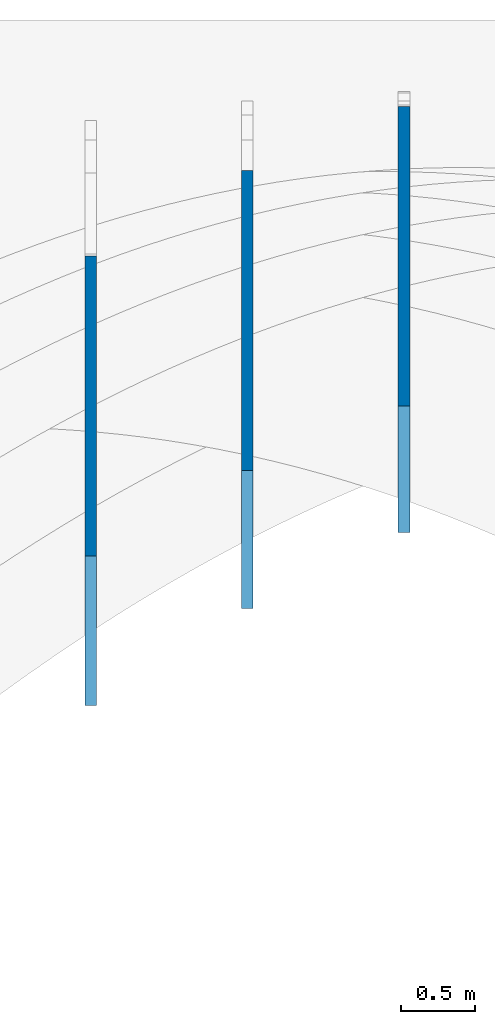
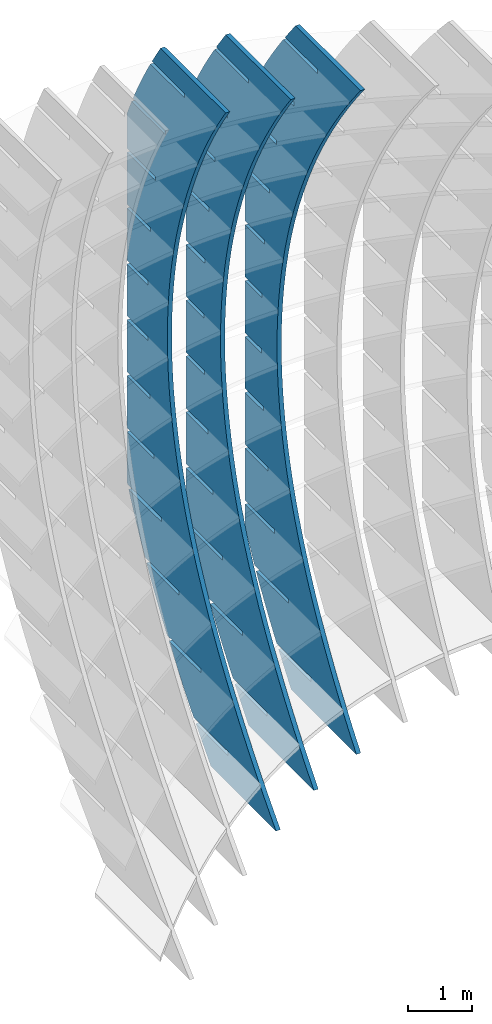
# Not in any storey, part 6 of 9: 3 walls.
"""IFC2X3 building model written with IfcOpenShell, lengths in metres."""

from ifc_helpers import new_model, si_unit, point, direction, frame, frame_2d, origin_with_axes, place, context, project, spatial, polyline, circle_curve, parameter, trimmed, segment, composite_curve, outline, extrude, material, type_object, element, save


model = new_model("IFC2X3")

# Units and contexts
model_context = context("Model", 3, precision=2.54e-06, world=origin_with_axes(), true_north=direction((0.0, 1.0)), identifier="Body")
ifc_project = project(units=[si_unit("LENGTHUNIT", "METRE"), si_unit("AREAUNIT", "SQUARE_METRE"), si_unit("VOLUMEUNIT", "CUBIC_METRE"), si_unit("PLANEANGLEUNIT", "RADIAN")], contexts=[model_context])

# Building
building_placement = place(None, origin_with_axes())
building = spatial("IfcBuilding", under=ifc_project, at=building_placement, Name="Building", CompositionType="ELEMENT")

# Walls
ifc_material = material(Name="MATERIAL")
wall_type = type_object("IfcWallType", Name="WALL", PredefinedType="NOTDEFINED", material=ifc_material)
wall_1_placement = place(None, origin_with_axes())
element("IfcWall", 1, at=wall_1_placement, inside=building, type_object=wall_type, context=model_context, shape_type="SweptSolid", body=[
    extrude(outline(composite_curve([segment(trimmed(circle_curve(frame_2d((0.0, 14.0556096878523), x_axis=(0.0, -1.0)), 14.0556096878523), [parameter(0.0), point((0.0, -14.0556096878523))], [parameter(0.152910259142259), point((2.14088125277144, 0.164001027989352))], True, "PARAMETER"), True, "CONTINUOUS"), segment(trimmed(circle_curve(frame_2d((0.499152866211186, 10.755598163582), x_axis=(0.15317376, -0.98819927)), 10.7180782782145), [parameter(0.0), point((2.14088125277144, 0.164001027989352))], [parameter(0.157260226364034), point((3.77940247591487, 0.551816292335879))], True, "PARAMETER"), True, "CONTINUOUS"), segment(trimmed(circle_curve(frame_2d((1.24461979826399, 8.56422366702772), x_axis=(0.30162352, -0.95342711)), 8.40379647307901), [parameter(0.0), point((3.77940247591487, 0.551816292335879))], [parameter(0.370756791575622), point((6.51023533727501, 2.0146367978992))], True, "PARAMETER"), True, "CONTINUOUS"), segment(trimmed(circle_curve(frame_2d((1.11975235900537, 8.58435154328559), x_axis=(0.63431294, -0.77307638)), 8.49814441950489), [parameter(0.0), point((6.51023533727501, 2.0146367978992))], [parameter(0.367999511734118), point((8.51278875206777, 4.39371060595666))], True, "PARAMETER"), True, "CONTINUOUS"), segment(trimmed(circle_curve(frame_2d((-1.00872629168969, 9.8555131764565), x_axis=(0.86742032, -0.49757612)), 10.976818120367), [parameter(0.0), point((8.51278875206777, 4.39371060595666))], [parameter(0.154777641958024), point((9.24096066700134, 5.92684249842083))], True, "PARAMETER"), True, "CONTINUOUS"), segment(trimmed(circle_curve(frame_2d((-4.2668643769205, 11.0916853869908), x_axis=(0.93404985, -0.35714267)), 14.4615676702359), [parameter(0.0), point((9.24096066700134, 5.92684249842083))], [parameter(0.150037105083515), point((9.86122140865234, 8.00394648670981))], True, "PARAMETER"), True, "CONTINUOUS"), segment(polyline([(9.86122140865234, 8.00394648670981), (11.1255954478323, 6.4132289476579)]), True, "CONTINUOUS"), segment(polyline([(11.1255954478323, 6.4132289476579), (11.0036056354265, 5.90731381827246)]), True, "CONTINUOUS"), segment(polyline([(11.0036056354265, 5.90731381827246), (10.3780921969592, 6.69427651020513)]), True, "CONTINUOUS"), segment(polyline([(10.3780921969592, 6.69427651020513), (10.3164518923209, 6.64528201618691)]), True, "CONTINUOUS"), segment(polyline([(10.3164518923209, 6.64528201618691), (10.9788979123445, 5.81185419334877)]), True, "CONTINUOUS"), segment(trimmed(circle_curve(frame_2d((-2.59831687475339, 9.34734780811046), x_axis=(0.94281805, -0.33330785)), 14.0299849064427), [parameter(0.0850680879933644), point((10.9788979123445, 5.81185419334877))], [parameter(0.0), point((10.6294061626564, 4.6710437418005))], False, "PARAMETER"), True, "CONTINUOUS"), segment(polyline([(10.6294061626564, 4.6710437418005), (10.0006085929895, 5.46213822143035)]), True, "CONTINUOUS"), segment(polyline([(10.0006085929895, 5.46213822143035), (9.93896828835126, 5.41314372741213)]), True, "CONTINUOUS"), segment(polyline([(9.93896828835126, 5.41314372741213), (10.5981302647537, 4.58384758208814)]), True, "CONTINUOUS"), segment(trimmed(circle_curve(frame_2d((-0.675686957104537, 8.66194192527583), x_axis=(0.91026997, -0.4140152)), 11.9887367234336), [parameter(0.0797731157945741), point((10.5981302647537, 4.58384758208814))], [parameter(0.0), point((10.2373000497545, 3.69842272898651))], False, "PARAMETER"), True, "CONTINUOUS"), segment(polyline([(10.2373000497545, 3.69842272898651), (10.1198493671014, 3.605067629552)]), True, "CONTINUOUS"), segment(polyline([(10.1198493671014, 3.605067629552), (9.5051460412784, 4.3784300455777)]), True, "CONTINUOUS"), segment(polyline([(9.5051460412784, 4.3784300455777), (9.44350573664014, 4.32943555155948)]), True, "CONTINUOUS"), segment(polyline([(9.44350573664014, 4.32943555155948), (10.0582090624632, 3.55607313553378)]), True, "CONTINUOUS"), segment(polyline([(10.0582090624632, 3.55607313553378), (9.28833792623328, 2.94414483634434)]), True, "CONTINUOUS"), segment(polyline([(9.28833792623328, 2.94414483634434), (8.81210590192627, 3.54329557042206)]), True, "CONTINUOUS"), segment(polyline([(8.81210590192627, 3.54329557042206), (8.750465597288, 3.49430107640384)]), True, "CONTINUOUS"), segment(polyline([(8.750465597288, 3.49430107640384), (9.22669762159501, 2.89515034232612)]), True, "CONTINUOUS"), segment(polyline([(9.22669762159501, 2.89515034232612), (8.45682648536513, 2.28322204313667)]), True, "CONTINUOUS"), segment(polyline([(8.45682648536513, 2.28322204313667), (8.07484401931951, 2.76379676985542)]), True, "CONTINUOUS"), segment(polyline([(8.07484401931951, 2.76379676985542), (8.01320371468124, 2.7148022758372)]), True, "CONTINUOUS"), segment(polyline([(8.01320371468124, 2.7148022758372), (8.39518618072687, 2.23422754911845)]), True, "CONTINUOUS"), segment(polyline([(8.39518618072687, 2.23422754911845), (7.62531504449699, 1.62229924992901)]), True, "CONTINUOUS"), segment(polyline([(7.62531504449699, 1.62229924992901), (7.29336039345813, 2.03993364387778)]), True, "CONTINUOUS"), segment(polyline([(7.29336039345813, 2.03993364387778), (7.23172008881986, 1.99093914985956)]), True, "CONTINUOUS"), segment(polyline([(7.23172008881986, 1.99093914985956), (7.56367473985872, 1.57330475591079)]), True, "CONTINUOUS"), segment(polyline([(7.56367473985872, 1.57330475591079), (6.79380360362885, 0.96137645672135)]), True, "CONTINUOUS"), segment(polyline([(6.79380360362885, 0.96137645672135), (6.46765502434213, 1.37170619248912)]), True, "CONTINUOUS"), segment(polyline([(6.46765502434213, 1.37170619248912), (6.40601471970386, 1.32271169847091)]), True, "CONTINUOUS"), segment(polyline([(6.40601471970386, 1.32271169847091), (6.73216329899058, 0.91238196270313)]), True, "CONTINUOUS"), segment(polyline([(6.73216329899058, 0.91238196270313), (5.96229216276071, 0.300453663513688)]), True, "CONTINUOUS"), segment(polyline([(5.96229216276071, 0.300453663513688), (5.5977279119715, 0.75911441568947)]), True, "CONTINUOUS"), segment(polyline([(5.5977279119715, 0.75911441568947), (5.53608760733324, 0.710119921671251)]), True, "CONTINUOUS"), segment(polyline([(5.53608760733324, 0.710119921671251), (5.90065185812244, 0.251459169495468)]), True, "CONTINUOUS"), segment(polyline([(5.90065185812244, 0.251459169495468), (5.13078072189256, -0.360469129693974)]), True, "CONTINUOUS"), segment(polyline([(5.13078072189256, -0.360469129693974), (4.68357905634626, 0.202158313478812)]), True, "CONTINUOUS"), segment(polyline([(4.68357905634626, 0.202158313478812), (4.62193875170799, 0.153163819460592)]), True, "CONTINUOUS"), segment(polyline([(4.62193875170799, 0.153163819460592), (5.0691404172543, -0.409463623712194)]), True, "CONTINUOUS"), segment(polyline([(5.0691404172543, -0.409463623712194), (4.29926928102442, -1.02139192290164)]), True, "CONTINUOUS"), segment(polyline([(4.29926928102442, -1.02139192290164), (3.72520845746639, -0.29916211414285)]), True, "CONTINUOUS"), segment(polyline([(3.72520845746639, -0.29916211414285), (3.66356815282812, -0.348156608161071)]), True, "CONTINUOUS"), segment(polyline([(3.66356815282812, -0.348156608161071), (4.23762897638617, -1.07038641691987)]), True, "CONTINUOUS"), segment(polyline([(4.23762897638617, -1.07038641691987), (3.90183265240795, -1.33729247916333)]), True, "CONTINUOUS"), segment(polyline([(3.90183265240795, -1.33729247916333), (3.27981607987049, -1.44586391504662)]), True, "CONTINUOUS"), segment(polyline([(3.27981607987049, -1.44586391504662), (2.62151491671479, -0.617650764696427)]), True, "CONTINUOUS"), segment(polyline([(2.62151491671479, -0.617650764696427), (2.55987461207652, -0.666645258714647)]), True, "CONTINUOUS"), segment(polyline([(2.55987461207652, -0.666645258714647), (3.18953299499016, -1.45882273331828)]), True, "CONTINUOUS"), segment(trimmed(circle_curve(frame_2d((1.34396518195871, 11.8563872213524), x_axis=(0.05035758, -0.99873125)), 13.4425048517551), [parameter(0.0873495783940598), point((3.18953299499016, -1.45882273331828))], [parameter(0.0), point((2.02089717425208, -1.56906248311816))], False, "PARAMETER"), True, "CONTINUOUS"), segment(polyline([(2.02089717425208, -1.56906248311816), (1.35927227903134, -0.736667722953974)]), True, "CONTINUOUS"), segment(polyline([(1.35927227903134, -0.736667722953974), (1.29763197439307, -0.785662216972194)]), True, "CONTINUOUS"), segment(polyline([(1.29763197439307, -0.785662216972194), (1.92397075368322, -1.57366327578196)]), True, "CONTINUOUS"), segment(polyline([(1.92397075368322, -1.57366327578196), (1.26437403918018, -1.5907175390521)]), True, "CONTINUOUS"), segment(polyline([(1.26437403918018, -1.5907175390521), (0.0, 0.0)]), True, "CONTINUOUS")], self_intersect="UNKNOWN")), frame((12.0254746225481, -1.04159282145464, -6.51240052652916), z_axis=(1.0, 0.0, 0.0), x_axis=(0.0, 0.62223132, 0.78283343)), (0.0, 0.0, 1.0), 0.07874),
])
wall_2_placement = place(None, origin_with_axes())
element("IfcWall", 2, at=wall_2_placement, inside=building, type_object=wall_type, context=model_context, shape_type="SweptSolid", body=[
    extrude(outline(composite_curve([segment(trimmed(circle_curve(frame_2d((0.0, 15.445268467474), x_axis=(0.0, -1.0)), 15.445268467474), [parameter(0.0), point((0.0, -15.445268467474))], [parameter(0.143600182175668), point((2.21032851497452, 0.158975068214743))], True, "PARAMETER"), True, "CONTINUOUS"), segment(trimmed(circle_curve(frame_2d((0.540039487599654, 11.6528636526297), x_axis=(0.14380921, -0.98960543)), 11.6146175238754), [parameter(0.0), point((2.21032851497452, 0.158975068214743))], [parameter(0.149054810640147), point((3.89869072374298, 0.534464392850162))], True, "PARAMETER"), True, "CONTINUOUS"), segment(trimmed(circle_curve(frame_2d((1.41923441114199, 8.92769073347869), x_axis=(0.28330825, -0.9590289)), 8.75179707323687), [parameter(0.0), point((3.89869072374298, 0.534464392850162))], [parameter(0.36083375302866), point((6.7022862887996, 1.95034776719877))], True, "PARAMETER"), True, "CONTINUOUS"), segment(trimmed(circle_curve(frame_2d((1.67158373960536, 8.46085203154184), x_axis=(0.61143672, -0.79129333)), 8.22767487899825), [parameter(0.0), point((6.7022862887996, 1.95034776719877))], [parameter(0.376044781359796), point((8.74171005055002, 4.25277077498477))], True, "PARAMETER"), True, "CONTINUOUS"), segment(trimmed(circle_curve(frame_2d((0.0139785871215013, 9.48852269447505), x_axis=(0.85753137, -0.51443168)), 10.1777401548756), [parameter(0.0), point((8.74171005055002, 4.25277077498477))], [parameter(0.162781677766597), point((9.47485750518521, 5.7364346414166))], True, "PARAMETER"), True, "CONTINUOUS"), segment(trimmed(circle_curve(frame_2d((-2.79221437025761, 10.587326898635), x_axis=(0.9299317, -0.36773229)), 13.1913686965539), [parameter(0.0), point((9.47485750518521, 5.7364346414166))], [parameter(0.159511743790453), point((10.0896235975151, 7.74647162944755))], True, "PARAMETER"), True, "CONTINUOUS"), segment(polyline([(10.0896235975151, 7.74647162944755), (11.4163107560334, 6.20734032139646)]), True, "CONTINUOUS"), segment(polyline([(11.4163107560334, 6.20734032139646), (11.2966308784954, 5.71776428293869)]), True, "CONTINUOUS"), segment(polyline([(11.2966308784954, 5.71776428293869), (10.6385699106068, 6.48120141412701)]), True, "CONTINUOUS"), segment(polyline([(10.6385699106068, 6.48120141412701), (10.5789285724198, 6.42979228673442)]), True, "CONTINUOUS"), segment(polyline([(10.5789285724198, 6.42979228673442), (11.2723025607412, 5.6253874149744)]), True, "CONTINUOUS"), segment(trimmed(circle_curve(frame_2d((-1.10002815984809, 8.90519628411253), x_axis=(0.93952079, -0.34249188)), 12.799676311443), [parameter(0.0904359883612036), point((11.2723025607412, 5.6253874149744))], [parameter(0.0), point((10.9255338359417, 4.5214111202238))], False, "PARAMETER"), True, "CONTINUOUS"), segment(polyline([(10.9255338359417, 4.5214111202238), (10.264026882487, 5.28884604715356)]), True, "CONTINUOUS"), segment(polyline([(10.264026882487, 5.28884604715356), (10.2043855443, 5.23743691976097)]), True, "CONTINUOUS"), segment(polyline([(10.2043855443, 5.23743691976097), (10.8943136389498, 4.43702973713223)]), True, "CONTINUOUS"), segment(polyline([(10.8943136389498, 4.43702973713223), (10.7011190569048, 3.95446130411277)]), True, "CONTINUOUS"), segment(polyline([(10.7011190569048, 3.95446130411277), (10.3057019337804, 3.61362305544396)]), True, "CONTINUOUS"), segment(polyline([(10.3057019337804, 3.61362305544396), (9.71319708496554, 4.30100648048698)]), True, "CONTINUOUS"), segment(polyline([(9.71319708496554, 4.30100648048698), (9.65355574677857, 4.2495973530944)]), True, "CONTINUOUS"), segment(polyline([(9.65355574677857, 4.2495973530944), (10.2460605955934, 3.56221392805137)]), True, "CONTINUOUS"), segment(polyline([(10.2460605955934, 3.56221392805137), (9.50115602275378, 2.92012749530938)]), True, "CONTINUOUS"), segment(polyline([(9.50115602275378, 2.92012749530938), (9.03074628449113, 3.46586456009011)]), True, "CONTINUOUS"), segment(polyline([(9.03074628449113, 3.46586456009011), (8.97110494630416, 3.41445543269752)]), True, "CONTINUOUS"), segment(polyline([(8.97110494630416, 3.41445543269752), (9.44151468456681, 2.86871836791679)]), True, "CONTINUOUS"), segment(polyline([(9.44151468456681, 2.86871836791679), (8.69661011172717, 2.22663193517479)]), True, "CONTINUOUS"), segment(polyline([(8.69661011172717, 2.22663193517479), (8.30189432653862, 2.68455407519465)]), True, "CONTINUOUS"), segment(polyline([(8.30189432653862, 2.68455407519465), (8.24225298835165, 2.63314494780207)]), True, "CONTINUOUS"), segment(polyline([(8.24225298835165, 2.63314494780207), (8.63696877354019, 2.17522280778221)]), True, "CONTINUOUS"), segment(polyline([(8.63696877354019, 2.17522280778221), (7.89206420070055, 1.53313637504021)]), True, "CONTINUOUS"), segment(polyline([(7.89206420070055, 1.53313637504021), (7.52664121110802, 1.95707502580061)]), True, "CONTINUOUS"), segment(polyline([(7.52664121110802, 1.95707502580061), (7.46699987292105, 1.90566589840803)]), True, "CONTINUOUS"), segment(polyline([(7.46699987292105, 1.90566589840803), (7.83242286251357, 1.48172724764762)]), True, "CONTINUOUS"), segment(polyline([(7.83242286251357, 1.48172724764762), (7.08751828967393, 0.839640814905623)]), True, "CONTINUOUS"), segment(polyline([(7.08751828967393, 0.839640814905623), (6.70498693819932, 1.28342741190799)]), True, "CONTINUOUS"), segment(polyline([(6.70498693819932, 1.28342741190799), (6.64534560001235, 1.2320182845154)]), True, "CONTINUOUS"), segment(polyline([(6.64534560001235, 1.2320182845154), (7.02787695148695, 0.788231687513038)]), True, "CONTINUOUS"), segment(polyline([(7.02787695148695, 0.788231687513038), (6.28297237864731, 0.146145254771038)]), True, "CONTINUOUS"), segment(polyline([(6.28297237864731, 0.146145254771038), (5.83693150781253, 0.663611233516784)]), True, "CONTINUOUS"), segment(polyline([(5.83693150781253, 0.663611233516784), (5.77729016962556, 0.612202106124199)]), True, "CONTINUOUS"), segment(polyline([(5.77729016962556, 0.612202106124199), (6.22333104046033, 0.0947361273784517)]), True, "CONTINUOUS"), segment(polyline([(6.22333104046033, 0.0947361273784517), (5.47842646762069, -0.54735030536355)]), True, "CONTINUOUS"), segment(polyline([(5.47842646762069, -0.54735030536355), (4.92247491994764, 0.0976264906269959)]), True, "CONTINUOUS"), segment(polyline([(4.92247491994764, 0.0976264906269959), (4.86283358176066, 0.0462173632344115)]), True, "CONTINUOUS"), segment(polyline([(4.86283358176066, 0.0462173632344115), (5.41878512943372, -0.598759432756133)]), True, "CONTINUOUS"), segment(polyline([(5.41878512943372, -0.598759432756133), (4.81210309797442, -1.12170198887898)]), True, "CONTINUOUS"), segment(polyline([(4.81210309797442, -1.12170198887898), (4.61415992126649, -1.17156208674202)]), True, "CONTINUOUS"), segment(polyline([(4.61415992126649, -1.17156208674202), (3.92513506398551, -0.372202778063052)]), True, "CONTINUOUS"), segment(polyline([(3.92513506398551, -0.372202778063052), (3.86549372579854, -0.423611905455638)]), True, "CONTINUOUS"), segment(polyline([(3.86549372579854, -0.423611905455638), (4.52790391662217, -1.19209470633484)]), True, "CONTINUOUS"), segment(trimmed(circle_curve(frame_2d((1.73189799575214, 10.8281033492428), x_axis=(0.13578445, -0.9907384)), 12.3411024793109), [parameter(0.0923396645129757), point((4.52790391662217, -1.19209470633484))], [parameter(0.0), point((3.40762776462875, -1.39870081810009))], False, "PARAMETER"), True, "CONTINUOUS"), segment(polyline([(3.40762776462875, -1.39870081810009), (2.71516316936996, -0.595350961702372)]), True, "CONTINUOUS"), segment(polyline([(2.71516316936996, -0.595350961702372), (2.65552183118299, -0.646760089094958)]), True, "CONTINUOUS"), segment(polyline([(2.65552183118299, -0.646760089094958), (3.31449228402836, -1.41125234225547)]), True, "CONTINUOUS"), segment(trimmed(circle_curve(frame_2d((1.41045251838668, 13.2250541584096), x_axis=(0.04727464, -0.99888193)), 14.7596353413814), [parameter(0.0820714178844645), point((3.31449228402836, -1.41125234225547))], [parameter(0.0), point((2.1082089801859, -1.51807886447847))], False, "PARAMETER"), True, "CONTINUOUS"), segment(polyline([(2.1082089801859, -1.51807886447847), (1.4122568468151, -0.710683005930992)]), True, "CONTINUOUS"), segment(polyline([(1.4122568468151, -0.710683005930992), (1.35261550862813, -0.762092133323578)]), True, "CONTINUOUS"), segment(polyline([(1.35261550862813, -0.762092133323578), (2.00810275526855, -1.52254340991473)]), True, "CONTINUOUS"), segment(polyline([(2.00810275526855, -1.52254340991473), (1.3266871585179, -1.53913130805092)]), True, "CONTINUOUS"), segment(polyline([(1.3266871585179, -1.53913130805092), (0.0, 0.0)]), True, "CONTINUOUS")], self_intersect="UNKNOWN")), frame((10.9632928043663, -1.55831109043057, -6.51240052652858), z_axis=(1.0, 0.0, 0.0), x_axis=(0.0, 0.65289722, 0.75744651)), (0.0, 0.0, 1.0), 0.07874),
])
wall_3_placement = place(None, origin_with_axes())
element("IfcWall", 3, at=wall_3_placement, inside=building, type_object=wall_type, context=model_context, shape_type="SweptSolid", body=[
    extrude(outline(composite_curve([segment(trimmed(circle_curve(frame_2d((0.0, 17.0163939093369), x_axis=(0.0, -1.0)), 17.0163939093369), [parameter(0.0), point((0.0, -17.0163939093369))], [parameter(0.134621094893436), point((2.28385265024627, 0.153959958400843))], True, "PARAMETER"), True, "CONTINUOUS"), segment(trimmed(circle_curve(frame_2d((0.577588747685051, 12.6976130681067), x_axis=(0.13478482, -0.99087489)), 12.659169397785), [parameter(0.0), point((2.28385265024627, 0.153959958400843))], [parameter(0.140733672158727), point((4.02647625723087, 0.517311561644895))], True, "PARAMETER"), True, "CONTINUOUS"), segment(trimmed(circle_curve(frame_2d((1.58069421230469, 9.40218826838084), x_axis=(0.26540273, -0.96413764)), 9.21536130084883), [parameter(0.0), point((4.02647625723087, 0.517311561644895))], [parameter(0.348595328362743), point((6.91424894737371, 1.88713152919349))], True, "PARAMETER"), True, "CONTINUOUS"), segment(trimmed(circle_curve(frame_2d((2.18585199980801, 8.42175512798452), x_axis=(0.58621927, -0.81015243)), 8.06591862540313), [parameter(0.0), point((6.91424894737371, 1.88713152919349))], [parameter(0.381070817871894), point((9.00538893908424, 4.11444051148943))], True, "PARAMETER"), True, "CONTINUOUS"), segment(trimmed(circle_curve(frame_2d((-0.102757661470506, 9.76590848998136), x_axis=(0.84971809, -0.5272373)), 10.7190216348842), [parameter(0.0), point((9.00538893908424, 4.11444051148943))], [parameter(0.341776740389491), point((10.3727347538627, 7.49401864550959))], True, "PARAMETER"), True, "CONTINUOUS"), segment(polyline([(10.3727347538627, 7.49401864550959), (11.7557776330849, 6.00532243935044)]), True, "CONTINUOUS"), segment(polyline([(11.7557776330849, 6.00532243935044), (11.6357139353998, 5.53174426733467)]), True, "CONTINUOUS"), segment(polyline([(11.6357139353998, 5.53174426733467), (10.9479065782304, 6.27209456201404)]), True, "CONTINUOUS"), segment(polyline([(10.9479065782304, 6.27209456201404), (10.8902196002417, 6.21850165044418)]), True, "CONTINUOUS"), segment(polyline([(10.8902196002417, 6.21850165044418), (11.6112541700612, 5.44238585192069)]), True, "CONTINUOUS"), segment(trimmed(circle_curve(frame_2d((0.304936424886239, 8.55904439322991), x_axis=(0.93418047, -0.35680086)), 11.7280169431142), [parameter(0.0958647745136909), point((11.6112541700612, 5.44238585192069))], [parameter(0.0), point((11.2610207565612, 4.37447780453773))], False, "PARAMETER"), True, "CONTINUOUS"), segment(polyline([(11.2610207565612, 4.37447780453773), (10.5696210334231, 5.11869489298643)]), True, "CONTINUOUS"), segment(polyline([(10.5696210334231, 5.11869489298643), (10.5119340554344, 5.06510198141657)]), True, "CONTINUOUS"), segment(polyline([(10.5119340554344, 5.06510198141657), (11.2293763550833, 4.29285287354644)]), True, "CONTINUOUS"), segment(polyline([(11.2293763550833, 4.29285287354644), (11.0905521329676, 3.95601778070782)]), True, "CONTINUOUS"), segment(polyline([(11.0905521329676, 3.95601778070782), (10.6125318897889, 3.51192281309979)]), True, "CONTINUOUS"), segment(polyline([(10.6125318897889, 3.51192281309979), (10.0012093110574, 4.16994550883048)]), True, "CONTINUOUS"), segment(polyline([(10.0012093110574, 4.16994550883048), (9.94352233306878, 4.11635259726062)]), True, "CONTINUOUS"), segment(polyline([(9.94352233306878, 4.11635259726062), (10.5548449118002, 3.45832990152993)]), True, "CONTINUOUS"), segment(polyline([(10.5548449118002, 3.45832990152993), (9.83434978202387, 2.78896858077909)]), True, "CONTINUOUS"), segment(polyline([(9.83434978202387, 2.78896858077909), (9.32612262947486, 3.33602019084361)]), True, "CONTINUOUS"), segment(polyline([(9.32612262947486, 3.33602019084361), (9.26843565148619, 3.28242727927375)]), True, "CONTINUOUS"), segment(polyline([(9.26843565148619, 3.28242727927375), (9.7766628040352, 2.73537566920922)]), True, "CONTINUOUS"), segment(polyline([(9.7766628040352, 2.73537566920922), (9.05616767425885, 2.06601434845838)]), True, "CONTINUOUS"), segment(polyline([(9.05616767425885, 2.06601434845838), (8.60266373743881, 2.55416233024902)]), True, "CONTINUOUS"), segment(polyline([(8.60266373743881, 2.55416233024902), (8.54497675945014, 2.50056941867916)]), True, "CONTINUOUS"), segment(polyline([(8.54497675945014, 2.50056941867916), (8.99848069627018, 2.01242143688852)]), True, "CONTINUOUS"), segment(polyline([(8.99848069627018, 2.01242143688852), (8.27798556649383, 1.34306011613767)]), True, "CONTINUOUS"), segment(polyline([(8.27798556649383, 1.34306011613767), (7.8308326349493, 1.8243719270467)]), True, "CONTINUOUS"), segment(polyline([(7.8308326349493, 1.8243719270467), (7.77314565696064, 1.77077901547684)]), True, "CONTINUOUS"), segment(polyline([(7.77314565696064, 1.77077901547684), (8.22029858850516, 1.28946720456781)]), True, "CONTINUOUS"), segment(polyline([(8.22029858850516, 1.28946720456781), (7.49980345872881, 0.620105883816967)]), True, "CONTINUOUS"), segment(polyline([(7.49980345872881, 0.620105883816967), (7.01062932200634, 1.14664898123667)]), True, "CONTINUOUS"), segment(polyline([(7.01062932200634, 1.14664898123667), (6.95294234401767, 1.0930560696668)]), True, "CONTINUOUS"), segment(polyline([(6.95294234401767, 1.0930560696668), (7.44211648074014, 0.566512972247106)]), True, "CONTINUOUS"), segment(polyline([(7.44211648074014, 0.566512972247106), (6.72162135096379, -0.102848348503741)]), True, "CONTINUOUS"), segment(polyline([(6.72162135096379, -0.102848348503741), (6.14205379860991, 0.520993492818906)]), True, "CONTINUOUS"), segment(polyline([(6.14205379860991, 0.520993492818906), (6.08436682062125, 0.467400581249045)]), True, "CONTINUOUS"), segment(polyline([(6.08436682062125, 0.467400581249045), (6.66393437297512, -0.156441260073602)]), True, "CONTINUOUS"), segment(polyline([(6.66393437297512, -0.156441260073602), (5.98157197107985, -0.790376146913311)]), True, "CONTINUOUS"), segment(polyline([(5.98157197107985, -0.790376146913311), (5.9277610470093, -0.808926696831752)]), True, "CONTINUOUS"), segment(polyline([(5.9277610470093, -0.808926696831752), (5.21126035292512, -0.0376911256010313)]), True, "CONTINUOUS"), segment(polyline([(5.21126035292512, -0.0376911256010313), (5.15357337493645, -0.0912840371708927)]), True, "CONTINUOUS"), segment(polyline([(5.15357337493645, -0.0912840371708927), (5.84591470363922, -0.836514662259415)]), True, "CONTINUOUS"), segment(trimmed(circle_curve(frame_2d((2.28165977108762, 9.92734953902013), x_axis=(0.2202407, -0.97544556)), 11.3386368566863), [parameter(0.0977064081270845), point((5.84591470363922, -0.836514662259415))], [parameter(0.0), point((4.77888911915982, -1.132873395032))], False, "PARAMETER"), True, "CONTINUOUS"), segment(polyline([(4.77888911915982, -1.132873395032), (4.05880257208346, -0.357778040546731)]), True, "CONTINUOUS"), segment(polyline([(4.05880257208346, -0.357778040546731), (4.00111559409479, -0.411370952116593)]), True, "CONTINUOUS"), segment(polyline([(4.00111559409479, -0.411370952116593), (4.68987106980525, -1.1527417939506)]), True, "CONTINUOUS"), segment(trimmed(circle_curve(frame_2d((1.81433459632557, 12.0359521462664), x_axis=(0.1273426, -0.99185879)), 13.4985316927075), [parameter(0.0869815694130236), point((4.68987106980525, -1.1527417939506))], [parameter(0.0), point((3.53327277040375, -1.35268517844762))], False, "PARAMETER"), True, "CONTINUOUS"), segment(polyline([(3.53327277040375, -1.35268517844762), (2.80960037033488, -0.573730040707879)]), True, "CONTINUOUS"), segment(polyline([(2.80960037033488, -0.573730040707879), (2.75191339234622, -0.627322952277739)]), True, "CONTINUOUS"), segment(polyline([(2.75191339234622, -0.627322952277739), (3.43708301506436, -1.36483401085723)]), True, "CONTINUOUS"), segment(trimmed(circle_curve(frame_2d((1.47073293492357, 14.7677787732059), x_axis=(0.04430783, -0.99901793)), 16.2520068877104), [parameter(0.0769660328198831), point((3.43708301506436, -1.36483401085723))], [parameter(0.0), point((2.19082410640473, -1.46826743832423))], False, "PARAMETER"), True, "CONTINUOUS"), segment(polyline([(2.19082410640473, -1.46826743832423), (1.46351602273091, -0.685398880060156)]), True, "CONTINUOUS"), segment(polyline([(1.46351602273091, -0.685398880060156), (1.40582904474224, -0.738991791630017)]), True, "CONTINUOUS"), segment(polyline([(1.40582904474224, -0.738991791630017), (2.08736749977501, -1.47259429058467)]), True, "CONTINUOUS"), segment(polyline([(2.08736749977501, -1.47259429058467), (1.38304287922313, -1.48869620615917)]), True, "CONTINUOUS"), segment(polyline([(1.38304287922313, -1.48869620615917), (0.0, 0.0)]), True, "CONTINUOUS")], self_intersect="UNKNOWN")), frame((9.90111098618421, -2.21716859907731, -6.51240052652958), z_axis=(1.0, 0.0, 0.0), x_axis=(0.0, 0.68063134, 0.73262609)), (0.0, 0.0, 1.0), 0.07874),
])

save(model, "model.ifc")
